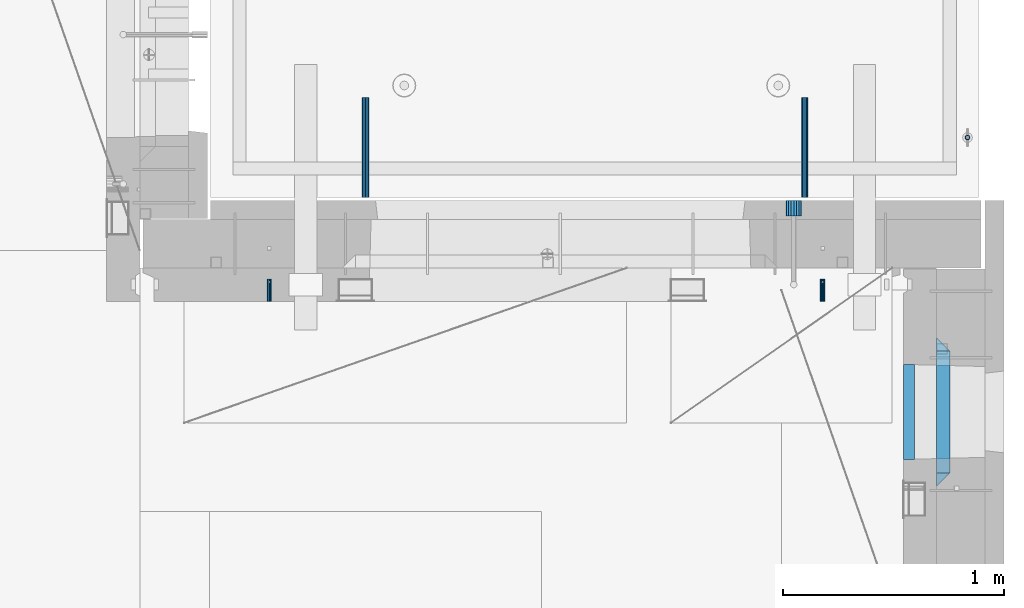
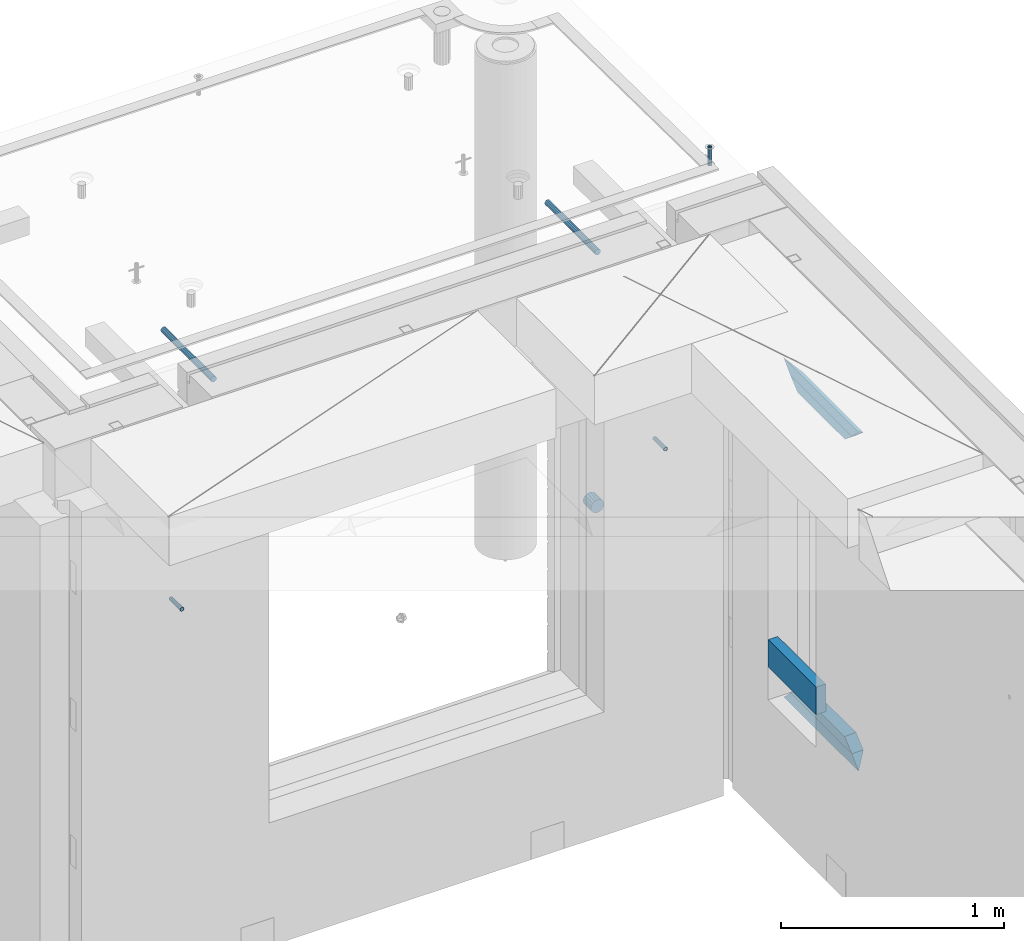
# One storey, part 170 of 350: 11 beams, 8 elements without a shape of their own.
"""IFC2X3 building model written with IfcOpenShell, lengths in millimetres."""

from ifc_helpers import new_model, si_unit, frame, origin_with_axes, place, context, subcontext, project, spatial, faceted_brep, material, type_object, element, aggregate, save


model = new_model("IFC2X3")

# Units and contexts
model_context = context("Model", 3, precision=1e-05, world=origin_with_axes())
body_context = subcontext(model_context, "Body", "Model", "MODEL_VIEW")
ifc_project = project(units=[si_unit("LENGTHUNIT", "METRE", prefix="MILLI"), si_unit("AREAUNIT", "SQUARE_METRE"), si_unit("VOLUMEUNIT", "CUBIC_METRE"), si_unit("MASSUNIT", "GRAM", prefix="KILO"), si_unit("TIMEUNIT", "SECOND"), si_unit("PLANEANGLEUNIT", "RADIAN"), si_unit("SOLIDANGLEUNIT", "STERADIAN"), si_unit("THERMODYNAMICTEMPERATUREUNIT", "DEGREE_CELSIUS"), si_unit("LUMINOUSINTENSITYUNIT", "LUMEN")], contexts=[model_context])

# Site, building, storey
site_placement = place(None, origin_with_axes())
site = spatial("IfcSite", under=ifc_project, at=site_placement, CompositionType="ELEMENT")
building_placement = place(site_placement, origin_with_axes())
building = spatial("IfcBuilding", under=site, at=building_placement, CompositionType="ELEMENT")
storey_placement = place(building_placement, origin_with_axes())
storey = spatial("IfcBuildingStorey", under=building, at=storey_placement, Name="2", CompositionType="ELEMENT", Elevation=0.0)

# Assemblies, beams
assembly_1_placement = place(storey_placement, origin_with_axes())
assembly_1 = element("IfcElementAssembly", 1, at=assembly_1_placement, inside=storey, AssemblyPlace="NOTDEFINED", PredefinedType="REINFORCEMENT_UNIT")
assembly_2_placement = place(assembly_1_placement, origin_with_axes())
assembly_2 = element("IfcElementAssembly", 2, at=assembly_2_placement, Name="Steel Assembly", AssemblyPlace="NOTDEFINED", PredefinedType="RIGID_FRAME")
ifc_material_1 = material(Name="STEEL/Steel_Undefined")
beam_type_1 = type_object("IfcBeamType", PredefinedType="NOTDEFINED")
beam_1_placement = place(assembly_2_placement, frame((32044.9982931989, 20429.9951872276, 86755.0), z_axis=(1.0, 0.0, 0.0), x_axis=(0.0, 1.0, 0.0)))
beam_1 = element("IfcBeam", 3, at=beam_1_placement, type_object=beam_type_1, material=ifc_material_1, Name="M16", context=body_context, shape_type="Brep", body=[
    faceted_brep([(0.0, -8.49999999999272, -1.45519152283669e-11), (0.0, -7.36121593215648, 4.24999999998545), (100.000000000262, -7.36121593215648, 4.24999999998545), (100.000000000262, -8.49999999999272, -1.45519152283669e-11), (0.0, -4.24999999998545, 7.36121593216376), (100.000000000262, -4.24999999998545, 7.36121593216376), (0.0, 1.45519152283669e-11, 8.49999999998545), (100.000000000262, 1.45519152283669e-11, 8.49999999998545), (0.0, 4.25000000001455, 7.36121593216376), (100.000000000262, 4.25000000001455, 7.36121593216376), (0.0, 7.36121593217104, 4.24999999998545), (100.000000000262, 7.36121593217104, 4.24999999998545), (0.0, 8.50000000000728, 0.0), (100.000000000262, 8.50000000000728, 0.0), (0.0, 7.36121593217104, -4.25000000001455), (100.000000000262, 7.36121593217104, -4.25000000001455), (0.0, 4.25000000000728, -7.36121593219286), (100.000000000262, 4.25000000000728, -7.36121593219286), (0.0, 7.27595761418343e-12, -8.5), (100.000000000262, 7.27595761418343e-12, -8.5), (0.0, -4.24999999999272, -7.36121593217831), (100.000000000262, -4.24999999999272, -7.36121593217831), (0.0, -7.36121593215648, -4.25), (100.000000000262, -7.36121593215648, -4.25), (0.0, -10.4999999999927, -1.45519152283669e-11), (0.0, -9.09326673972828, -5.25000000001455), (100.000000000262, -9.09326673972828, -5.25000000001455), (100.000000000262, -10.4999999999927, -1.45519152283669e-11), (0.0, -5.24999999998545, -9.09326673974283), (100.000000000262, -5.24999999998545, -9.09326673974283), (0.0, 7.27595761418343e-12, -10.5), (100.000000000262, 7.27595761418343e-12, -10.5), (0.0, 5.25000000001455, -9.09326673975738), (100.000000000262, 5.25000000001455, -9.09326673975738), (0.0, 9.09326673975011, -5.25000000001455), (100.000000000262, 9.09326673975011, -5.25000000001455), (0.0, 10.5000000000073, -1.45519152283669e-11), (100.000000000262, 10.5000000000073, -1.45519152283669e-11), (0.0, 9.09326673975011, 5.25), (100.000000000262, 9.09326673975011, 5.25), (0.0, 5.25000000000728, 9.09326673972828), (100.000000000262, 5.25000000000728, 9.09326673972828), (0.0, 1.45519152283669e-11, 10.4999999999854), (100.000000000262, 1.45519152283669e-11, 10.4999999999854), (0.0, -5.24999999999272, 9.09326673972828), (100.000000000262, -5.24999999999272, 9.09326673972828), (0.0, -9.09326673972828, 5.24999999998545), (100.000000000262, -9.09326673972828, 5.24999999998545)], [[[0, 1, 2, 3]], [[1, 4, 5, 2]], [[4, 6, 7, 5]], [[6, 8, 9, 7]], [[8, 10, 11, 9]], [[10, 12, 13, 11]], [[12, 14, 15, 13]], [[14, 16, 17, 15]], [[16, 18, 19, 17]], [[18, 20, 21, 19]], [[20, 22, 23, 21]], [[22, 0, 3, 23]], [[24, 25, 26, 27]], [[25, 28, 29, 26]], [[28, 30, 31, 29]], [[30, 32, 33, 31]], [[32, 34, 35, 33]], [[34, 36, 37, 35]], [[36, 38, 39, 37]], [[38, 40, 41, 39]], [[40, 42, 43, 41]], [[42, 44, 45, 43]], [[44, 46, 47, 45]], [[46, 24, 27, 47]], [[29, 31, 33, 35, 37, 39, 41, 43, 45, 47, 27, 26], [5, 7, 9, 11, 13, 15, 17, 19, 21, 23, 3, 2]], [[46, 44, 42, 40, 38, 36, 34, 32, 30, 28, 25, 24], [22, 20, 18, 16, 14, 12, 10, 8, 6, 4, 1, 0]]]),
])
aggregate(assembly_2, [beam_1])
assembly_3_placement = place(assembly_1_placement, origin_with_axes())
assembly_3 = element("IfcElementAssembly", 4, at=assembly_3_placement, Name="Steel Assembly", AssemblyPlace="NOTDEFINED", PredefinedType="RIGID_FRAME")
beam_2_placement = place(assembly_3_placement, frame((34544.998293199, 20429.9951872276, 86755.0), z_axis=(1.0, 0.0, 0.0), x_axis=(0.0, 1.0, 0.0)))
beam_2 = element("IfcBeam", 5, at=beam_2_placement, type_object=beam_type_1, material=ifc_material_1, Name="M16", context=body_context, shape_type="Brep", body=[
    faceted_brep([(0.0, -8.49999999999272, -1.45519152283669e-11), (0.0, -7.36121593215648, 4.24999999998545), (100.000000000262, -7.36121593215648, 4.24999999998545), (100.000000000262, -8.49999999999272, -1.45519152283669e-11), (0.0, -4.24999999998545, 7.36121593216376), (100.000000000262, -4.24999999998545, 7.36121593216376), (0.0, 1.45519152283669e-11, 8.49999999998545), (100.000000000262, 1.45519152283669e-11, 8.49999999998545), (0.0, 4.25000000001455, 7.36121593216376), (100.000000000262, 4.25000000001455, 7.36121593216376), (0.0, 7.36121593217104, 4.24999999998545), (100.000000000262, 7.36121593217104, 4.24999999998545), (0.0, 8.50000000000728, 0.0), (100.000000000262, 8.50000000000728, 0.0), (0.0, 7.36121593217104, -4.25000000001455), (100.000000000262, 7.36121593217104, -4.25000000001455), (0.0, 4.25000000000728, -7.36121593219286), (100.000000000262, 4.25000000000728, -7.36121593219286), (0.0, 7.27595761418343e-12, -8.5), (100.000000000262, 7.27595761418343e-12, -8.5), (0.0, -4.24999999999272, -7.36121593217831), (100.000000000262, -4.24999999999272, -7.36121593217831), (0.0, -7.36121593215648, -4.25), (100.000000000262, -7.36121593215648, -4.25), (0.0, -10.4999999999927, -1.45519152283669e-11), (0.0, -9.09326673972828, -5.25000000001455), (100.000000000262, -9.09326673972828, -5.25000000001455), (100.000000000262, -10.4999999999927, -1.45519152283669e-11), (0.0, -5.24999999998545, -9.09326673974283), (100.000000000262, -5.24999999998545, -9.09326673974283), (0.0, 7.27595761418343e-12, -10.5), (100.000000000262, 7.27595761418343e-12, -10.5), (0.0, 5.25000000001455, -9.09326673975738), (100.000000000262, 5.25000000001455, -9.09326673975738), (0.0, 9.09326673975011, -5.25000000001455), (100.000000000262, 9.09326673975011, -5.25000000001455), (0.0, 10.5000000000073, -1.45519152283669e-11), (100.000000000262, 10.5000000000073, -1.45519152283669e-11), (0.0, 9.09326673975011, 5.25), (100.000000000262, 9.09326673975011, 5.25), (0.0, 5.25000000000728, 9.09326673972828), (100.000000000262, 5.25000000000728, 9.09326673972828), (0.0, 1.45519152283669e-11, 10.4999999999854), (100.000000000262, 1.45519152283669e-11, 10.4999999999854), (0.0, -5.24999999999272, 9.09326673972828), (100.000000000262, -5.24999999999272, 9.09326673972828), (0.0, -9.09326673972828, 5.24999999998545), (100.000000000262, -9.09326673972828, 5.24999999998545)], [[[0, 1, 2, 3]], [[1, 4, 5, 2]], [[4, 6, 7, 5]], [[6, 8, 9, 7]], [[8, 10, 11, 9]], [[10, 12, 13, 11]], [[12, 14, 15, 13]], [[14, 16, 17, 15]], [[16, 18, 19, 17]], [[18, 20, 21, 19]], [[20, 22, 23, 21]], [[22, 0, 3, 23]], [[24, 25, 26, 27]], [[25, 28, 29, 26]], [[28, 30, 31, 29]], [[30, 32, 33, 31]], [[32, 34, 35, 33]], [[34, 36, 37, 35]], [[36, 38, 39, 37]], [[38, 40, 41, 39]], [[40, 42, 43, 41]], [[42, 44, 45, 43]], [[44, 46, 47, 45]], [[46, 24, 27, 47]], [[29, 31, 33, 35, 37, 39, 41, 43, 45, 47, 27, 26], [5, 7, 9, 11, 13, 15, 17, 19, 21, 23, 3, 2]], [[46, 44, 42, 40, 38, 36, 34, 32, 30, 28, 25, 24], [22, 20, 18, 16, 14, 12, 10, 8, 6, 4, 1, 0]]]),
])
aggregate(assembly_3, [beam_2])

# Assemblies, beam
assembly_4_placement = place(storey_placement, origin_with_axes())
assembly_4 = element("IfcElementAssembly", 6, at=assembly_4_placement, inside=storey, AssemblyPlace="NOTDEFINED", PredefinedType="REINFORCEMENT_UNIT")
assembly_5_placement = place(assembly_4_placement, origin_with_axes())
assembly_5 = element("IfcElementAssembly", 7, at=assembly_5_placement, Name="Steel Assembly", AssemblyPlace="NOTDEFINED", PredefinedType="RIGID_FRAME")
ifc_material_2 = material(Name="STEEL/1.4301")
beam_type_2 = type_object("IfcBeamType", PredefinedType="NOTDEFINED")
beam_3_placement = place(assembly_5_placement, frame((35199.9998195516, 21170.0002421324, 87731.000000009), z_axis=(0.999999999984675, 3.40399999908427e-06, -4.36599999368485e-06), x_axis=(-4.36599999292741e-06, 0.0, -0.999999999990469)))
beam_3 = element("IfcBeam", 8, at=beam_3_placement, type_object=beam_type_2, material=ifc_material_2, context=body_context, shape_type="Brep", body=[
    faceted_brep([(0.0, -8.0, 0.0), (0.0, -6.92820323027263, 4.0), (100.000000000029, -6.92820323027263, 4.0), (100.000000000029, -7.99999999999636, 0.0), (0.0, -4.0, 6.92820323027627), (100.000000000029, -4.0, 6.92820323027536), (0.0, 0.0, 8.0), (100.000000000029, 3.63797880709171e-12, 8.0), (0.0, 4.0, 6.92820323027627), (100.000000000029, 4.0, 6.92820323027536), (0.0, 6.92820323027263, 4.0), (100.000000000029, 6.92820323027627, 3.99999999999909), (0.0, 8.0, 0.0), (100.000000000029, 8.0, 0.0), (0.0, 6.92820323027263, -4.0), (100.000000000029, 6.92820323027627, -4.00000000000091), (0.0, 4.0, -6.92820323027627), (100.000000000029, 4.00000000000364, -6.92820323027536), (0.0, 0.0, -8.0), (100.000000000029, 3.63797880709171e-12, -8.00000000000091), (0.0, -4.0, -6.92820323027627), (100.000000000029, -3.99999999999636, -6.92820323027627), (0.0, -6.92820323027263, -4.0), (100.000000000029, -6.92820323027263, -4.0), (0.0, -10.4999999999927, -1.45519152283669e-11), (0.0, -9.09326673972828, -5.25000000001455), (100.000000000262, -9.09326673972828, -5.25000000001455), (100.000000000262, -10.4999999999927, -1.45519152283669e-11), (0.0, -5.24999999998545, -9.09326673974283), (100.000000000262, -5.24999999998545, -9.09326673974283), (0.0, 7.27595761418343e-12, -10.5), (100.000000000262, 7.27595761418343e-12, -10.5), (0.0, 5.25000000001455, -9.09326673975738), (100.000000000262, 5.25000000001455, -9.09326673975738), (0.0, 9.09326673975011, -5.25000000001455), (100.000000000262, 9.09326673975011, -5.25000000001455), (0.0, 10.5000000000073, -1.45519152283669e-11), (100.000000000262, 10.5000000000073, -1.45519152283669e-11), (0.0, 9.09326673975011, 5.25), (100.000000000262, 9.09326673975011, 5.25), (0.0, 5.25000000000728, 9.09326673972828), (100.000000000262, 5.25000000000728, 9.09326673972828), (0.0, 1.45519152283669e-11, 10.4999999999854), (100.000000000262, 1.45519152283669e-11, 10.4999999999854), (0.0, -5.24999999999272, 9.09326673972828), (100.000000000262, -5.24999999999272, 9.09326673972828), (0.0, -9.09326673972828, 5.24999999998545), (100.000000000262, -9.09326673972828, 5.24999999998545)], [[[0, 1, 2, 3]], [[1, 4, 5, 2]], [[4, 6, 7, 5]], [[6, 8, 9, 7]], [[8, 10, 11, 9]], [[10, 12, 13, 11]], [[12, 14, 15, 13]], [[14, 16, 17, 15]], [[16, 18, 19, 17]], [[18, 20, 21, 19]], [[20, 22, 23, 21]], [[22, 0, 3, 23]], [[24, 25, 26, 27]], [[25, 28, 29, 26]], [[28, 30, 31, 29]], [[30, 32, 33, 31]], [[32, 34, 35, 33]], [[34, 36, 37, 35]], [[36, 38, 39, 37]], [[38, 40, 41, 39]], [[40, 42, 43, 41]], [[42, 44, 45, 43]], [[44, 46, 47, 45]], [[46, 24, 27, 47]], [[29, 31, 33, 35, 37, 39, 41, 43, 45, 47, 27, 26], [5, 7, 9, 11, 13, 15, 17, 19, 21, 23, 3, 2]], [[46, 44, 42, 40, 38, 36, 34, 32, 30, 28, 25, 24], [22, 20, 18, 16, 14, 12, 10, 8, 6, 4, 1, 0]]]),
])
aggregate(assembly_5, [beam_3])

# Beam
ifc_material_3 = material()
beam_type_3 = type_object("IfcBeamType", Name="D70", PredefinedType="NOTDEFINED")
beam_4_placement = place(assembly_1_placement, frame((34415.0, 20884.9951872276, 86255.0), z_axis=(0.0, 0.0, 1.0), x_axis=(0.0, -1.0, 0.0)))
beam_4 = element("IfcBeam", 9, at=beam_4_placement, type_object=beam_type_3, material=ifc_material_3, ObjectType="D70", context=body_context, shape_type="Brep", body=[
    faceted_brep([(0.0, -35.0, 0.0), (0.0, -32.3357836378964, -13.3939201327739), (70.0, -32.3357836378964, -13.3939201327739), (70.0, -35.0, 0.0), (0.0, -24.7487373415279, -24.7487373415352), (70.0, -24.7487373415279, -24.7487373415352), (0.0, -13.3939201327776, -32.3357836379), (70.0, -13.3939201327776, -32.3357836379), (0.0, 0.0, -35.0), (70.0, 0.0, -35.0), (0.0, 13.3939201327776, -32.3357836379), (70.0, 13.3939201327776, -32.3357836379), (0.0, 24.7487373415279, -24.7487373415352), (70.0, 24.7487373415279, -24.7487373415352), (0.0, 32.3357836378964, -13.3939201327739), (70.0, 32.3357836378964, -13.3939201327739), (0.0, 35.0, 0.0), (70.0, 35.0, 0.0), (0.0, 32.3357836378964, 13.3939201327739), (70.0, 32.3357836378964, 13.3939201327739), (0.0, 24.7487373415279, 24.7487373415352), (70.0, 24.7487373415279, 24.7487373415352), (0.0, 13.3939201327776, 32.3357836379), (70.0, 13.3939201327776, 32.3357836379), (0.0, 0.0, 35.0), (70.0, 0.0, 35.0), (0.0, -13.3939201327776, 32.3357836379), (70.0, -13.3939201327776, 32.3357836379), (0.0, -24.7487373415279, 24.7487373415352), (70.0, -24.7487373415279, 24.7487373415352), (0.0, -32.3357836378964, 13.3939201327739), (70.0, -32.3357836378964, 13.3939201327739)], [[[0, 1, 2, 3]], [[1, 4, 5, 2]], [[4, 6, 7, 5]], [[6, 8, 9, 7]], [[8, 10, 11, 9]], [[10, 12, 13, 11]], [[12, 14, 15, 13]], [[14, 16, 17, 15]], [[16, 18, 19, 17]], [[18, 20, 21, 19]], [[20, 22, 23, 21]], [[22, 24, 25, 23]], [[24, 26, 27, 25]], [[26, 28, 29, 27]], [[28, 30, 31, 29]], [[30, 0, 3, 31]], [[5, 7, 9, 11, 13, 15, 17, 19, 21, 23, 25, 27, 29, 31, 3, 2]], [[30, 28, 26, 24, 22, 20, 18, 16, 14, 12, 10, 8, 6, 4, 1, 0]]]),
])

aggregate(assembly_1, [beam_4, assembly_2, assembly_3])

# Assembly, beam
assembly_6_placement = place(assembly_4_placement, origin_with_axes())
assembly_6 = element("IfcElementAssembly", 10, at=assembly_6_placement, Name="Steel Assembly", AssemblyPlace="NOTDEFINED", PredefinedType="RIGID_FRAME")
ifc_material_4 = material(Name="STEEL/S235JR")
beam_type_4 = type_object("IfcBeamType", Name="D30", PredefinedType="NOTDEFINED")
beam_5_placement = place(assembly_6_placement, frame((32479.9998567563, 20900.0253394533, 87575.0), z_axis=(0.0, 0.0, 1.0), x_axis=(0.0, 1.0, 0.0)))
beam_5 = element("IfcBeam", 11, at=beam_5_placement, type_object=beam_type_4, material=ifc_material_4, Name="Rd30", ObjectType="D30", context=body_context, shape_type="Brep", body=[
    faceted_brep([(0.0, -15.0, 0.0), (0.0, -12.9903810567666, -7.5), (450.0, -12.9903810567666, -7.5), (450.0, -15.0, 0.0), (0.0, -7.5, -12.9903810567666), (450.0, -7.5, -12.990381056763), (0.0, 0.0, -15.0), (450.0, 0.0, -15.0), (0.0, 7.5, -12.9903810567666), (450.0, 7.5, -12.990381056763), (0.0, 12.9903810567666, -7.5), (450.0, 12.9903810567666, -7.5), (0.0, 15.0, 0.0), (450.0, 15.0, 0.0), (0.0, 12.9903810567666, 7.5), (450.0, 12.9903810567666, 7.5), (0.0, 7.5, 12.9903810567666), (450.0, 7.5, 12.990381056763), (0.0, 0.0, 15.0), (450.0, 0.0, 15.0), (0.0, -7.5, 12.9903810567666), (450.0, -7.5, 12.990381056763), (0.0, -12.9903810567666, 7.5), (450.0, -12.9903810567666, 7.5)], [[[0, 1, 2, 3]], [[1, 4, 5, 2]], [[4, 6, 7, 5]], [[6, 8, 9, 7]], [[8, 10, 11, 9]], [[10, 12, 13, 11]], [[12, 14, 15, 13]], [[14, 16, 17, 15]], [[16, 18, 19, 17]], [[18, 20, 21, 19]], [[20, 22, 23, 21]], [[22, 0, 3, 23]], [[5, 7, 9, 11, 13, 15, 17, 19, 21, 23, 3, 2]], [[22, 20, 18, 16, 14, 12, 10, 8, 6, 4, 1, 0]]]),
])
aggregate(assembly_6, [beam_5])

# Assembly
assembly_7_placement = place(assembly_4_placement, origin_with_axes())
assembly_7 = element("IfcElementAssembly", 12, at=assembly_7_placement, Name="Steel Assembly", AssemblyPlace="NOTDEFINED", PredefinedType="RIGID_FRAME")

aggregate(assembly_4, [assembly_5, assembly_6, assembly_7])

# Beam
beam_6_placement = place(assembly_7_placement, frame((34464.9998570066, 20900.0152136098, 87575.0), z_axis=(0.0, 0.0, 1.0), x_axis=(0.0, 1.0, 0.0)))
beam_6 = element("IfcBeam", 13, at=beam_6_placement, type_object=beam_type_4, material=ifc_material_4, Name="Rd30", ObjectType="D30", context=body_context, shape_type="Brep", body=[
    faceted_brep([(0.0, -15.0, 0.0), (0.0, -12.9903810567666, -7.5), (450.0, -12.9903810567666, -7.5), (450.0, -15.0, 0.0), (0.0, -7.5, -12.9903810567666), (450.0, -7.5, -12.990381056763), (0.0, 0.0, -15.0), (450.0, 0.0, -15.0), (0.0, 7.5, -12.9903810567666), (450.0, 7.5, -12.990381056763), (0.0, 12.9903810567666, -7.5), (450.0, 12.9903810567666, -7.5), (0.0, 15.0, 0.0), (450.0, 15.0, 0.0), (0.0, 12.9903810567666, 7.5), (450.0, 12.9903810567666, 7.5), (0.0, 7.5, 12.9903810567666), (450.0, 7.5, 12.990381056763), (0.0, 0.0, 15.0), (450.0, 0.0, 15.0), (0.0, -7.5, 12.9903810567666), (450.0, -7.5, 12.990381056763), (0.0, -12.9903810567666, 7.5), (450.0, -12.9903810567666, 7.5)], [[[0, 1, 2, 3]], [[1, 4, 5, 2]], [[4, 6, 7, 5]], [[6, 8, 9, 7]], [[8, 10, 11, 9]], [[10, 12, 13, 11]], [[12, 14, 15, 13]], [[14, 16, 17, 15]], [[16, 18, 19, 17]], [[18, 20, 21, 19]], [[20, 22, 23, 21]], [[22, 0, 3, 23]], [[5, 7, 9, 11, 13, 15, 17, 19, 21, 23, 3, 2]], [[22, 20, 18, 16, 14, 12, 10, 8, 6, 4, 1, 0]]]),
])

aggregate(assembly_7, [beam_6])

# Assembly, beams
assembly_8_placement = place(storey_placement, origin_with_axes())
assembly_8 = element("IfcElementAssembly", 14, at=assembly_8_placement, inside=storey, AssemblyPlace="NOTDEFINED", PredefinedType="REINFORCEMENT_UNIT")
ifc_material_5 = material(Name="TIMBER/T24")
beam_type_5 = type_object("IfcBeamType", PredefinedType="NOTDEFINED")
beam_7_placement = place(assembly_8_placement, frame((34935.0002758707, 19715.0011464907, 85685.0), z_axis=(0.0, 0.0, 1.0), x_axis=(0.0, 1.0, 0.0)))
beam_7 = element("IfcBeam", 15, at=beam_7_placement, type_object=beam_type_5, material=ifc_material_5, context=body_context, shape_type="Brep", body=[
    faceted_brep([(-3.63797880709171e-12, 24.9999999999964, -75.0), (-3.63797880709171e-12, 24.9999999999964, 75.0), (430.0, 25.0, 75.0), (430.0, 25.0, -75.0), (0.0, -25.0000000000073, 75.0), (430.0, -25.0, 75.0), (0.0, -25.0000000000073, -75.0), (430.0, -25.0, -75.0)], [[[0, 1, 2, 3]], [[1, 4, 5, 2]], [[4, 6, 7, 5]], [[6, 0, 3, 7]], [[5, 7, 3, 2]], [[6, 4, 1, 0]]]),
])
ifc_material_6 = material(Name="CONCRETE/C25/30")
beam_type_6 = type_object("IfcBeamType", PredefinedType="NOTDEFINED")
beam_8_placement = place(assembly_8_placement, frame((35090.0, 19595.0003479451, 87145.0), z_axis=(0.0, 0.0, -1.0), x_axis=(0.0, 1.0, 0.0)))
beam_8 = element("IfcBeam", 16, at=beam_8_placement, type_object=beam_type_6, material=ifc_material_6, Name="SK", context=body_context, shape_type="Brep", body=[
    faceted_brep([(60.0000000000073, 30.0, 30.0), (0.0, -30.0, -30.0), (60.0000000000073, -30.0, 30.0), (609.999618530263, 30.0, 30.0), (669.999575761092, -30.0, -30.0), (609.999618530263, -30.0, 30.0)], [[[0, 1, 2]], [[1, 0, 3, 4]], [[2, 1, 4, 5]], [[0, 2, 5, 3]], [[4, 3, 5]]]),
])
beam_9_placement = place(assembly_8_placement, frame((35090.0, 19655.0003479451, 87085.0), z_axis=(0.0, 0.0, -1.0), x_axis=(0.0, 1.0, 0.0)))
beam_9 = element("IfcBeam", 17, at=beam_9_placement, type_object=beam_type_6, material=ifc_material_6, Name="SK", context=body_context, shape_type="Brep", body=[
    faceted_brep([(65.6752942059502, 30.0, 25.6756756756804), (64.0536725843267, -30.0, 24.0540540540533), (485.94556447622, -30.0, 24.0540540540533), (484.323942854597, 30.0, 25.6756756756804), (65.6752942059502, 30.0, 26.293109307022), (64.0536725843267, -30.0, 24.9031479173718), (0.0, -30.0, -30.0), (0.0, 30.0, -30.0), (549.999575761092, 29.999999998452, -30.0), (549.999575761092, -29.999999998452, -30.0), (485.94556447622, -30.0, 24.9034748914273), (484.323942854597, 30.0, 26.293436281092)], [[[0, 1, 2, 3]], [[1, 0, 4, 5]], [[6, 5, 4, 7]], [[6, 7, 8, 9]], [[2, 1, 5, 6, 9, 10]], [[3, 2, 10, 11]], [[7, 4, 0, 3, 11, 8]], [[10, 9, 8, 11]]]),
])
beam_10_placement = place(assembly_8_placement, frame((35090.0, 20264.9999664753, 85350.0), z_axis=(0.0, 0.0, 1.0), x_axis=(0.0, -1.0, 0.0)))
beam_10 = element("IfcBeam", 18, at=beam_10_placement, type_object=beam_type_6, material=ifc_material_6, Name="SK", context=body_context, shape_type="Brep", body=[
    faceted_brep([(669.999575761092, -30.0, -30.0), (609.999618530263, 30.0, 30.0), (609.999618530263, -30.0, 30.0), (60.0000000000073, 30.0, 30.0), (60.0000000000073, -30.0, 30.0), (0.0, -30.0, -30.0)], [[[0, 1, 2]], [[3, 4, 2, 1]], [[4, 5, 0, 2]], [[5, 3, 1, 0]], [[3, 5, 4]]]),
])
beam_11_placement = place(assembly_8_placement, frame((35090.0, 20204.9999664753, 85410.0), z_axis=(0.0, 0.0, 1.0), x_axis=(0.0, -1.0, 0.0)))
beam_11 = element("IfcBeam", 19, at=beam_11_placement, type_object=beam_type_6, material=ifc_material_6, Name="SK", context=body_context, shape_type="Brep", body=[
    faceted_brep([(485.945945945947, -30.0, 24.0540540540533), (484.324324324325, 30.0, 25.6756756756804), (65.6756756756768, 30.0, 25.6756756756804), (64.0540540540533, -30.0, 24.0540540540533), (485.945945945947, -30.0, 24.9031479173718), (484.324324324323, 30.0, 26.2931093070365), (549.999575761092, -29.999999998452, -30.0), (549.999575761092, 29.999999998452, -30.0), (0.0, 30.0, -30.0), (65.6756756756768, 30.0, 26.293436281092), (64.0540540540533, -30.0, 24.9034748914419), (0.0, -30.0, -30.0)], [[[0, 1, 2, 3]], [[1, 0, 4, 5]], [[6, 7, 5, 4]], [[2, 1, 5, 7, 8, 9]], [[3, 2, 9, 10]], [[6, 4, 0, 3, 10, 11]], [[11, 8, 7, 6]], [[11, 10, 9, 8]]]),
])
aggregate(assembly_8, [beam_7, beam_8, beam_9, beam_10, beam_11])

save(model, "model.ifc")
